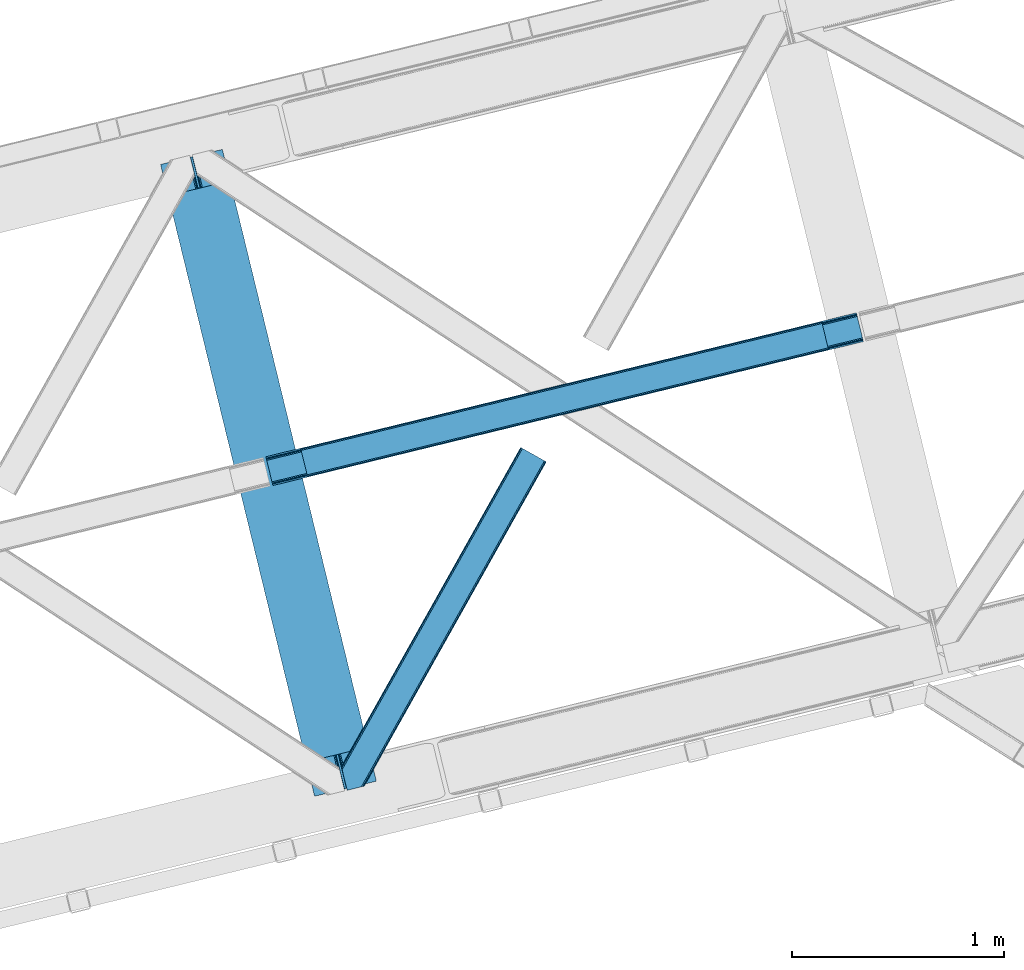
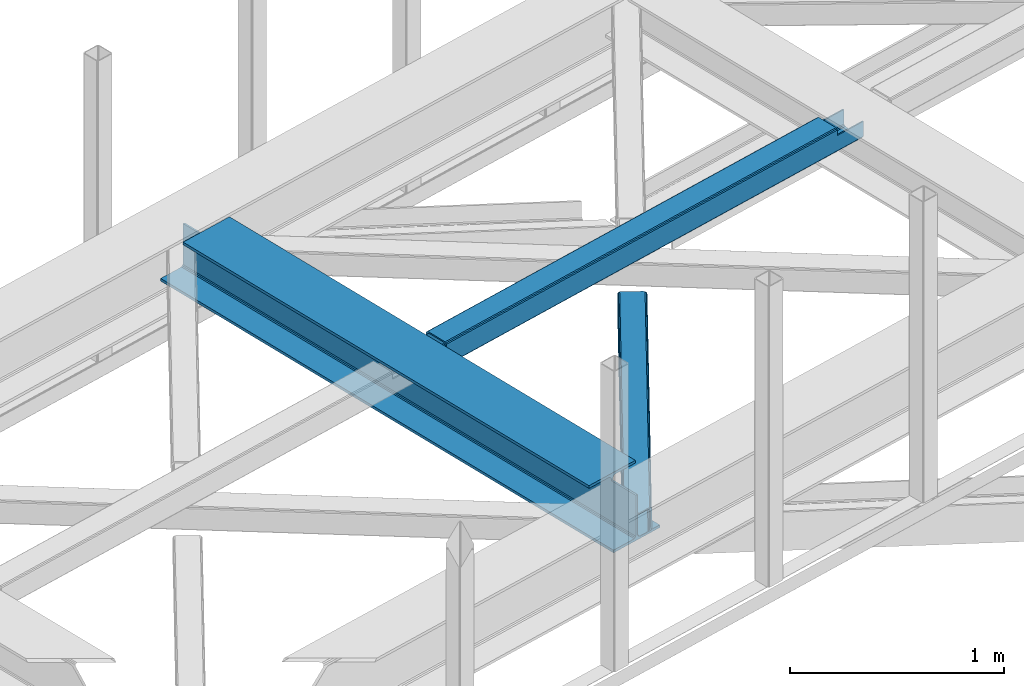
# One storey, part 55 of 66: 2 beams, 1 member.
"""IFC4 building model written with IfcOpenShell, lengths in millimetres."""

from ifc_helpers import new_model, entity, si_unit, converted_unit, derived_unit, direction, frame, origin, place, context, subcontext, project, spatial, triangles, polygons, material, type_object, element, save


model = new_model("IFC4")

# Units and contexts
model_context = context("Model", 3, precision=0.01, world=origin(), true_north=direction((6.12303176911189e-17, 1.0)))
plan_context = context("Plan", 3, precision=0.01, world=origin(), true_north=direction((6.12303176911189e-17, 1.0)))
body_context = subcontext(model_context, "Body", "Model", "MODEL_VIEW")
ifc_project = project(units=[si_unit("LENGTHUNIT", "METRE", prefix="MILLI"), si_unit("AREAUNIT", "SQUARE_METRE"), si_unit("VOLUMEUNIT", "CUBIC_METRE"), converted_unit("PLANEANGLEUNIT", "DEGREE", entity("IfcRatioMeasure", 0.0174532925199433), si_unit("PLANEANGLEUNIT", "RADIAN"), dimensions=[0, 0, 0, 0, 0, 0, 0]), si_unit("MASSUNIT", "GRAM", prefix="KILO"), derived_unit("MASSDENSITYUNIT", [(si_unit("MASSUNIT", "GRAM", prefix="KILO"), 1), (si_unit("LENGTHUNIT", "METRE"), -3)]), derived_unit("MOMENTOFINERTIAUNIT", [(si_unit("LENGTHUNIT", "METRE"), 4)]), si_unit("TIMEUNIT", "SECOND"), si_unit("FREQUENCYUNIT", "HERTZ"), si_unit("THERMODYNAMICTEMPERATUREUNIT", "DEGREE_CELSIUS"), derived_unit("THERMALTRANSMITTANCEUNIT", [(si_unit("MASSUNIT", "GRAM", prefix="KILO"), 1), (si_unit("THERMODYNAMICTEMPERATUREUNIT", "KELVIN"), -1), (si_unit("TIMEUNIT", "SECOND"), -3)]), derived_unit("VOLUMETRICFLOWRATEUNIT", [(si_unit("LENGTHUNIT", "METRE"), 3), (si_unit("TIMEUNIT", "SECOND"), -1)]), derived_unit("MASSFLOWRATEUNIT", [(si_unit("MASSUNIT", "GRAM", prefix="KILO"), 1), (si_unit("TIMEUNIT", "SECOND"), -1)]), derived_unit("ROTATIONALFREQUENCYUNIT", [(si_unit("TIMEUNIT", "SECOND"), -1)]), si_unit("ELECTRICCURRENTUNIT", "AMPERE"), si_unit("ELECTRICVOLTAGEUNIT", "VOLT"), si_unit("POWERUNIT", "WATT"), si_unit("FORCEUNIT", "NEWTON", prefix="KILO"), si_unit("ILLUMINANCEUNIT", "LUX"), si_unit("LUMINOUSFLUXUNIT", "LUMEN"), si_unit("LUMINOUSINTENSITYUNIT", "CANDELA"), derived_unit("USERDEFINED", [(si_unit("MASSUNIT", "GRAM", prefix="KILO"), -1), (si_unit("LENGTHUNIT", "METRE"), -2), (si_unit("TIMEUNIT", "SECOND"), 3), (si_unit("LUMINOUSFLUXUNIT", "LUMEN"), 1)]), derived_unit("LINEARVELOCITYUNIT", [(si_unit("LENGTHUNIT", "METRE"), 1), (si_unit("TIMEUNIT", "SECOND"), -1)]), si_unit("PRESSUREUNIT", "PASCAL"), derived_unit("USERDEFINED", [(si_unit("LENGTHUNIT", "METRE"), -2), (si_unit("MASSUNIT", "GRAM", prefix="KILO"), 1), (si_unit("TIMEUNIT", "SECOND"), -2)]), derived_unit("LINEARFORCEUNIT", [(si_unit("MASSUNIT", "GRAM", prefix="KILO"), 1), (si_unit("LENGTHUNIT", "METRE"), 1), (si_unit("TIMEUNIT", "SECOND"), -2), (si_unit("LENGTHUNIT", "METRE"), -1)]), derived_unit("PLANARFORCEUNIT", [(si_unit("MASSUNIT", "GRAM", prefix="KILO"), 1), (si_unit("LENGTHUNIT", "METRE"), 1), (si_unit("TIMEUNIT", "SECOND"), -2), (si_unit("LENGTHUNIT", "METRE"), -2)])], contexts=[model_context, plan_context])

# Site, building, storey
site_placement = place(None, origin())
site = spatial("IfcSite", under=ifc_project, at=site_placement, CompositionType="ELEMENT")
building_placement = place(site_placement, origin())
building = spatial("IfcBuilding", under=site, at=building_placement, CompositionType="ELEMENT")
storey_placement = place(building_placement, frame((0.0, 0.0, 19800.0)))
storey = spatial("IfcBuildingStorey", under=building, at=storey_placement, Name="06", CompositionType="ELEMENT", Elevation=19800.0)

# Beams
ifc_material = material(Name="Metal painted (White)")
beam_type = type_object("IfcBeamType", PredefinedType="BEAM")
beam_1_placement = place(storey_placement, frame((-9086.33, 15580.04, 3807.02)))
element("IfcBeam", 1, at=beam_1_placement, inside=storey, type_object=beam_type, material=ifc_material, ObjectType="Steel Beam", PredefinedType="BEAM", context=body_context, shape_type="Tessellation", body=[
    polygons([(1018.1664837833, 71.0478278971021, 15.5000000000008), (1018.1664837833, 71.0478278971021, 0.0), (291.465617442452, 3052.25531830421, 0.0), (291.465617442452, 3052.25531830421, 15.5000000000008), (894.779372399334, 40.9709140873313, 15.5000000000008), (168.078506058486, 3022.17840449444, 15.5000000000008), (888.087028625383, 39.3395844888265, 16.8701684147984), (161.386162284532, 3020.54707489594, 16.8701684147984), (882.413533524763, 37.956610033654, 20.7720779386478), (155.712667183913, 3019.16410044077, 20.7720779386478), (878.622625296189, 37.0325360459184, 26.6116982174294), (151.921758955338, 3018.24002645303, 26.6116982174294), (877.291435352789, 36.7080444135029, 33.500000000001), (150.590569011938, 3017.91553482062, 33.500000000001), (140.875048430526, 3015.54727389071, 33.500000000001), (140.875048430525, 3015.54727389071, 259.000000000002), (150.590569011936, 3017.91553482062, 259.000000000002), (0.0, 2981.20749040711, 0.0), (3.24860138789518e-12, 2981.20749040711, 15.4999999999965), (123.387111383965, 3011.28440421689, 15.5000000000008), (130.079455157938, 3012.91573381539, 16.8701684147984), (135.752950258554, 3014.29870827056, 20.7720779386391), (139.543858487129, 3015.2227822583, 26.6116982174294), (877.291435352786, 36.7080444135029, 259.000000000002), (867.575914771374, 34.3397834836014, 259.000000000002), (867.575914771377, 34.3397834836014, 33.500000000001), (866.24472482798, 34.0152918511859, 26.6116982174294), (862.453816599403, 33.0912178634502, 20.7720779386391), (856.780321498787, 31.70824340828, 16.8701684147984), (850.087977724816, 30.0769138097708, 15.5000000000008), (726.700866340855, 0.0, 15.4999999999965), (726.700866340851, 0.0, 0.0), (838.124523615913, 197.385937999181, 259.069791973884), (186.469722099971, 2870.72539801219, 259.000000000002), (186.693115201823, 2869.80895360721, 259.617303331124), (186.70550404545, 2869.75812937344, 266.500003008253), (837.979344808147, 197.981416001704, 266.500002998871), (837.979694928899, 197.979979696973, 260.000004007589), (828.499586345882, 194.645865944434, 259.006343171919), (828.27621632612, 195.562317481914, 259.617303331124), (828.263827482491, 195.613141715687, 266.500003008253), (176.989986719794, 2867.38985508742, 266.500002998871), (176.989636599042, 2867.39129139215, 260.000004007589), (176.844830940702, 2867.98534020594, 259.07612046749), (176.75420151856, 2868.35713708228, 259.000000000002), (839.310832678078, 198.30468544639, 273.388305639783), (843.101109266769, 199.231350618303, 279.227924098777), (848.774180214308, 200.616065081981, 283.129832400619), (855.466371895439, 202.248018612794, 284.500000377228), (978.853400583268, 232.325271667905, 284.500000138971), (978.851730776625, 232.332121736637, 299.999995328161), (687.386308679347, 161.283492472596, 299.999995890962), (687.387978486002, 161.276642403863, 284.500000701776), (810.775007173842, 191.353895458974, 284.500000463519), (817.467494070002, 192.984637925557, 283.129832461069), (823.141405718754, 194.365903570079, 279.227924137322), (826.93294050575, 195.287407219375, 273.388305663684), (175.658498849867, 2867.06658564273, 273.388305639783), (171.868222261169, 2866.13992047082, 279.227924098781), (166.195151313643, 2864.75520600715, 283.129832400619), (159.502959632494, 2863.12325247633, 284.500000377228), (36.1159309446587, 2833.04599942122, 284.500000138971), (36.117600751305, 2833.03914935249, 299.999995328161), (327.583022848581, 2904.08777861653, 299.999995890962), (327.581353041927, 2904.09462868526, 284.500000701776), (204.194324354092, 2874.01737563015, 284.500000463519), (197.50183745795, 2872.38663316357, 283.129832461069), (191.827925809185, 2871.00536751905, 279.227924137318), (188.036391022194, 2870.08386386975, 273.388305663684)], [[[1, 2, 3, 4]], [[5, 1, 4, 6]], [[7, 5, 6, 8]], [[9, 7, 8, 10]], [[11, 9, 10, 12]], [[13, 11, 12, 14]], [[15, 16, 17, 14, 12, 10, 8, 6, 4, 3, 18, 19, 20, 21, 22, 23]], [[13, 24, 25, 26, 27, 28, 29, 30, 31, 32, 2, 1, 5, 7, 9, 11]], [[2, 32, 18, 3]], [[32, 31, 19, 18]], [[31, 30, 20, 19]], [[27, 26, 15, 23]], [[28, 27, 23, 22]], [[29, 28, 22, 21]], [[30, 29, 21, 20]], [[33, 24, 13, 14, 17, 34, 35, 36, 37, 38]], [[25, 39, 40, 41, 42, 43, 44, 16, 15, 26]], [[39, 25, 24, 33]], [[45, 34, 17, 16]], [[41, 40, 38, 37, 46, 47, 48, 49, 50, 51, 52, 53, 54, 55, 56, 57]], [[42, 58, 59, 60, 61, 62, 63, 64, 65, 66, 67, 68, 69, 36, 35, 43]], [[46, 37, 36, 69]], [[47, 46, 69, 68]], [[48, 47, 68, 67]], [[49, 48, 67, 66]], [[50, 49, 66, 65]], [[51, 50, 65, 64]], [[52, 51, 64, 63]], [[53, 52, 63, 62]], [[54, 53, 62, 61]], [[55, 54, 61, 60]], [[56, 55, 60, 59]], [[57, 56, 59, 58]], [[41, 57, 58, 42]]], closed=False),
])
beam_2_placement = place(storey_placement, frame((-8589.6, 17046.14, 3967.02)))
element("IfcBeam", 2, at=beam_2_placement, inside=storey, type_object=beam_type, material=ifc_material, ObjectType="Steel Beam", PredefinedType="BEAM", context=body_context, shape_type="Tessellation", body=[
    polygons([(31.182392391782, 8.09507685196974, 17.8030399336114), (31.4978703677338, 6.80086440699434, 24.4999999999988), (2817.90917311747, 686.01809910328, 24.4999999999988), (2817.59369514152, 687.312311548251, 17.8030399336114), (30.2839871259284, 11.7806820741929, 12.1256313292298), (2816.69528987567, 690.997916770481, 12.1256313292298), (28.9394286278462, 17.2965800886818, 8.33210818105214), (2815.35073137759, 696.513814784967, 8.33210818105214), (27.35341374041, 23.8030254244748, 7.00000000000274), (2813.76471649015, 703.02026012076, 7.00000000000274), (4.21622439085534, 118.720708051138, 8.33210818105214), (5.80223927828939, 112.214262715347, 7.00000000000274), (2792.21354202803, 791.431497411635, 7.00000000000274), (2790.6275271406, 797.937942747428, 8.33210818105214), (2.87166589277206, 124.236606065627, 12.1256313292342), (2789.28296864251, 803.453840761912, 12.1256313292342), (1.97326062691843, 127.922211287854, 17.8030399336114), (2788.38456337666, 807.13944598414, 17.8030399336114), (1.65778265095143, 129.216423732823, 24.4999999999988), (2788.06908540069, 808.433658429109, 24.4999999999988), (33.1556530186549, 2.16573425859679e-12, 17.5000000000004), (33.1556530186528, 2.16573425859679e-12, 99.499999999999), (31.4978703677219, 6.80086440699217, 99.499999999999), (1.6577826509406, 129.216423732817, 99.499999999999), (6.49720277579036e-12, 136.017288139809, 99.499999999999), (9.74580416368554e-12, 136.017288139809, 17.5000000000004), (0.315477975968082, 134.72307569484, 10.803039933613), (1.21388324182172, 131.037470472617, 5.12563132923143), (2.55844173990608, 125.521572458128, 1.33210818105373), (4.14445662734013, 119.015127122333, 0.0), (29.0111963913267, 17.0021610174783, 0.0), (30.5972112787619, 10.4957156816875, 1.33210818105373), (31.9417697768441, 4.97981766719851, 5.12563132923576), (32.8401750426977, 1.29421244497107, 10.803039933613), (2786.41130274974, 815.234522836097, 17.5000000000004), (2786.41130274974, 815.234522836094, 99.499999999999), (2788.06908540067, 808.433658429104, 99.499999999999), (2817.90917311745, 686.018099103278, 99.499999999999), (2819.56695576838, 679.217234696288, 99.499999999999), (2819.56695576839, 679.217234696292, 17.5000000000004), (2819.25147779243, 680.511447141259, 10.803039933613), (2818.35307252658, 684.197052363484, 5.12563132923576), (2817.0085140285, 689.712950377975, 1.33210818105373), (2815.42249914106, 696.219395713764, 0.0), (2790.55575937708, 798.23236181862, 0.0), (2788.96974448964, 804.738807154411, 1.33210818105373), (2787.62518599156, 810.2547051689, 5.12563132923143), (2786.72678072571, 813.94031039113, 10.803039933613), (2653.72536552982, 645.996559503596, 115.5000123926), (2653.78173361469, 646.01029872221, 100.117303289864), (2654.6884273497, 646.231315480905, 99.499999999999), (194.718606580807, 46.58768115868, 99.5063429816656), (195.631369831918, 46.8101414945073, 100.117301735448), (195.690168193629, 46.8244741223611, 115.5), (2656.34621000063, 639.430451073913, 99.499999999999), (2655.43964990838, 639.209466900405, 100.117303484932), (2655.38006714071, 639.194943868063, 122.500007895425), (197.345360928044, 40.0229783796067, 122.500002534479), (197.338587096737, 40.0213271441522, 100.500009163303), (196.748205195732, 39.8773799905108, 99.5697919021647), (2624.8483491876, 768.646841677423, 99.5063429816656), (2623.93924032813, 768.425271514709, 100.117299778624), (2623.88287224327, 768.411532296091, 115.50000888136), (165.850080476843, 169.240033448186, 115.5), (165.840462203339, 169.237688832046, 100.50000941238), (165.250325295041, 169.093836777338, 99.5761204674868), (2622.81875057268, 775.357142845592, 99.5697919021647), (163.22074576778, 175.804071762186, 99.499999999999), (164.133244938518, 176.026503182401, 100.117301984524), (164.189439987629, 176.04020120897, 122.500002796667), (2622.22174126677, 775.211580304176, 122.500003994045), (2622.23184455559, 775.21404371874, 100.500018741102), (2622.53385542114, 773.916547682008, 129.196959150505), (2623.42719094673, 770.229706340318, 134.874360354937), (2624.7684819508, 764.713011635509, 138.667878733795), (2626.35352903681, 758.206330327434, 139.999985502214), (2651.22427808373, 656.194341778123, 139.999991354279), (2652.81177220132, 649.688257112721, 138.667885332354), (2654.16003176176, 644.173261502491, 134.874367586349), (2655.06379646897, 640.488963035541, 129.196966804773), (2653.41217589812, 647.291329899609, 122.196975799125), (2652.50841119091, 650.975628366566, 127.874376580702), (2651.16015163047, 656.490623976793, 131.667894326702), (2649.57265751289, 662.996708642196, 133.000000348631), (2628.01800833888, 751.407098718266, 132.999995276841), (2626.43296125288, 757.913780026341, 131.667888508414), (2625.09167024881, 763.430474731148, 127.874370129564), (2624.19833472322, 767.11731607284, 122.196968925133), (164.878528418714, 169.003207355196, 99.499999999999), (193.131726453735, 57.3201898040421, 131.667891818946), (191.5457115663, 63.826635139835, 133.0), (194.476284951818, 51.8042917895531, 127.874368670764), (195.374690217671, 48.11868656733, 122.196960066391), (169.994537104179, 152.237872430709, 133.0), (166.165558452806, 167.945821003219, 122.196960066391), (167.063963718659, 164.260215780991, 127.874368670764), (168.408522216743, 158.744317766505, 131.667891818946), (197.031411944066, 41.3175635421159, 129.196961104604), (196.136488323058, 45.0040174739003, 134.874366301861), (194.794244157307, 50.5204796458751, 138.667887185257), (193.209023953575, 57.0271186992015, 139.999994588639), (168.341882306934, 159.03998683839, 139.999994981919), (166.755021471182, 165.546225960036, 138.667887628704), (165.408105180725, 171.06154922293, 134.874366787843), (164.506189230959, 174.746298656826, 129.196961619)], [[[1, 2, 3, 4]], [[5, 1, 4, 6]], [[7, 5, 6, 8]], [[9, 7, 8, 10]], [[11, 12, 13, 14]], [[15, 11, 14, 16]], [[17, 15, 16, 18]], [[19, 17, 18, 20]], [[12, 9, 10, 13]], [[21, 22, 23, 2, 1, 5, 7, 9, 12, 11, 15, 17, 19, 24, 25, 26, 27, 28, 29, 30, 31, 32, 33, 34]], [[35, 36, 37, 20, 18, 16, 14, 13, 10, 8, 6, 4, 3, 38, 39, 40, 41, 42, 43, 44, 45, 46, 47, 48]], [[49, 50, 51, 38, 3, 2, 23, 52, 53, 54]], [[55, 39, 38, 51]], [[39, 55, 56, 57, 58, 59, 60, 22, 21, 40]], [[32, 31, 44, 43]], [[33, 32, 43, 42]], [[34, 33, 42, 41]], [[21, 34, 41, 40]], [[31, 30, 45, 44]], [[27, 26, 35, 48]], [[28, 27, 48, 47]], [[29, 28, 47, 46]], [[30, 29, 46, 45]], [[20, 37, 61, 62, 63, 64, 65, 66, 24, 19]], [[67, 36, 35, 26, 25, 68, 69, 70, 71, 72]], [[36, 67, 61, 37]], [[72, 71, 73, 74, 75, 76, 77, 78, 79, 80, 57, 56, 50, 49, 81, 82, 83, 84, 85, 86, 87, 88, 63, 62]], [[60, 52, 23, 22]], [[25, 24, 89, 68]], [[90, 91, 84, 83]], [[92, 90, 83, 82]], [[93, 92, 82, 81]], [[54, 93, 81, 49]], [[94, 85, 84, 91]], [[95, 64, 63, 88]], [[96, 95, 88, 87]], [[97, 96, 87, 86]], [[94, 97, 86, 85]], [[65, 64, 95, 96, 97, 94, 91, 90, 92, 93, 54, 53, 59, 58, 98, 99, 100, 101, 102, 103, 104, 105, 70, 69]], [[98, 58, 57, 80]], [[99, 98, 80, 79]], [[100, 99, 79, 78]], [[101, 100, 78, 77]], [[77, 76, 102, 101]], [[103, 102, 76, 75]], [[104, 103, 75, 74]], [[105, 104, 74, 73]], [[70, 105, 73, 71]]], closed=False),
])

# Member
member_type = type_object("IfcMemberType", PredefinedType="BRACE")
member_placement = place(storey_placement, frame((-8233.36, 15608.24, 3823.0)))
element("IfcMember", 3, at=member_placement, inside=storey, type_object=member_type, ObjectType="Steel Horizontal Brace", PredefinedType="BRACE", context=body_context, shape_type="Tessellation", body=[
    triangles([(967.681050109863, 1549.66471252441, 122.499499511719), (966.521237182617, 1550.31699829101, 129.196765136719), (108.493377685547, 19.761584472657, 122.499499511719), (106.721974182128, 19.3302154541016, 129.196765136719), (963.215043640136, 1552.17502441406, 134.87548828125), (101.679258728027, 18.1012207031254, 134.87548828125), (958.263020324707, 1554.95392456055, 138.668280029298), (94.1378585815428, 16.2629608154293, 138.668280029298), (952.422679138183, 1558.23395690918, 140.00075683594), (85.2360763549805, 14.0921630859375, 140.00075683594), (967.681050109863, 1549.66471252441, 17.5012573242202), (108.493377685547, 19.761584472657, 17.5012573242202), (6.07462921142542, 87.5702362060547, 140.00075683594), (27.4210006713856, 0.0, 140.00075683594), (860.874778747559, 1609.64826049805, 140.00075683594), (855.034437561035, 1612.92829284668, 138.668280029298), (3.74977111816406, 97.1068634033199, 138.668280029298), (850.082414245605, 1615.70719299316, 134.87548828125), (1.77896118164063, 105.192416381837, 134.87548828125), (846.776220703125, 1617.56521911621, 129.196765136719), (0.462181091308594, 110.594412231445, 129.196765136719), (845.616407775879, 1618.21750488281, 122.499499511719), (0.0, 112.491970825195, 122.499499511719), (845.616407775879, 1618.21750488281, 17.5012573242202), (0.0, 112.491970825195, 17.5012573242202), (966.521237182617, 1550.31699829101, 10.8039916992202), (106.721974182128, 19.3302154541016, 10.8039916992202), (156.767756652832, 115.413885498047, 5.52059326172093), (963.215043640136, 1552.17502441406, 5.12526855468968), (156.952047729492, 116.778918457032, 5.02062377929906), (102.189692687988, 18.2256317138672, 5.52059326172093), (958.263020324707, 1554.95392456055, 1.33247680664135), (157.131687927245, 118.142788696288, 4.52065429687718), (155.381794738769, 125.321420288086, 1.33247680664135), (952.422679138183, 1558.23395690918, 0.0), (153.056936645507, 134.858047485352, 0.0), (124.438916015624, 252.261346435547, 0.0), (94.4628387451166, 244.953652954102, 0.0), (860.874778747559, 1609.64826049805, 0.0), (77.5132919311518, 240.822509765625, 5.52059326172093), (85.5657073974608, 242.785180664063, 1.33247680664135), (123.842440795898, 252.116006469727, 5.44385375976708), (124.438916015624, 252.261346435547, 4.52065429687718), (846.776220703125, 1617.56521911621, 10.8039916992202), (1.68013000488281, 112.178036499023, 10.9621215820334), (0.251147460936409, 111.460638427734, 12.5201660156272), (850.082414245605, 1615.70719299316, 5.12526855468968), (855.034437561035, 1612.92829284668, 1.33247680664135), (6.66994171142505, 114.682534790039, 5.52059326172093), (34.2211669921871, 1.65687561035156, 5.52059326172093), (123.467463684082, 252.024151611327, 5.52059326172093), (32.7846267700188, 1.30689697265552, 6.99957275390625), (12.4672622680664, 84.6564605712883, 6.99957275390625), (9.18839263916016, 92.4908660888668, 8.3320495605476), (4.07649536132703, 95.7674102783203, 12.5201660156272), (75.9366439819332, 11.8260223388679, 6.99957275390625), (946.321307373047, 1561.66165466309, 6.99957275390625), (866.976150512695, 1606.22056274414, 6.99957275390625), (861.135809326172, 1609.49943237305, 8.3320495605476), (856.187855529784, 1612.28065795899, 12.1248413085959), (852.877592468261, 1614.1375213623, 17.8035644531265), (2.89226531982422, 100.625253295899, 17.8035644531265), (851.717779541015, 1614.78980712891, 24.5008300781265), (2.43008422851563, 102.522811889648, 24.5008300781265), (961.579678344727, 1553.09241027832, 24.5008300781265), (960.415214538574, 1553.7435333252, 17.8035644531265), (99.1892944335932, 17.4942810058601, 24.5008300781265), (97.4178909301754, 17.0617492675774, 17.8035644531265), (957.109602355957, 1555.60155944824, 12.1248413085959), (92.3798263549797, 15.8339172363285, 12.1248413085959), (952.16164855957, 1558.38278503418, 8.3320495605476), (84.8337753295891, 13.994494628907, 8.3320495605476), (961.579678344727, 1553.09241027832, 115.499926757813), (99.1892944335932, 17.4942810058601, 115.499926757813), (84.8337753295891, 13.994494628907, 131.668707275392), (75.9366439819332, 11.8260223388679, 133.001184082033), (27.4210006713856, 0.0, 133.001184082033), (92.3798263549797, 15.8339172363285, 127.873590087893), (97.4178909301754, 17.0617492675774, 122.197192382813), (946.321307373047, 1561.66165466309, 133.001184082033), (952.16164855957, 1558.38278503418, 131.668707275392), (957.109602355957, 1555.60155944824, 127.873590087893), (960.415214538574, 1553.7435333252, 122.197192382813), (856.187855529784, 1612.28065795899, 127.873590087893), (866.976150512695, 1606.22056274414, 133.001184082033), (861.135809326172, 1609.49943237305, 131.668707275392), (851.717779541015, 1614.78980712891, 115.499926757813), (852.877592468261, 1614.1375213623, 122.197192382813), (4.20904541015625, 95.2232574462887, 127.873590087893), (2.89226531982422, 100.625253295899, 122.197192382813), (6.17985534667969, 87.1377044677738, 131.668707275392), (8.50471343994104, 77.6010772705085, 133.001184082033), (2.43008422851563, 102.522811889648, 115.499926757813)], [[1, 2, 3], [4, 3, 2], [2, 5, 4], [6, 4, 5], [5, 7, 6], [8, 6, 7], [7, 9, 8], [10, 8, 9], [11, 1, 3], [3, 12, 11], [13, 10, 9], [10, 13, 14], [9, 15, 13], [15, 16, 17], [17, 13, 15], [16, 18, 19], [19, 17, 16], [18, 20, 21], [21, 19, 18], [20, 22, 23], [23, 21, 20], [22, 24, 25], [25, 23, 22], [26, 27, 28], [28, 29, 26], [28, 30, 29], [27, 31, 28], [30, 32, 29], [30, 33, 32], [33, 34, 32], [35, 32, 36], [34, 36, 32], [26, 11, 12], [12, 27, 26], [37, 38, 39], [36, 37, 35], [39, 35, 37], [38, 40, 41], [38, 37, 42], [38, 42, 40], [42, 37, 43], [43, 36, 33], [36, 43, 37], [34, 33, 36], [24, 44, 45], [45, 46, 24], [47, 48, 41], [45, 44, 40], [44, 47, 40], [40, 49, 45], [41, 40, 47], [48, 39, 38], [38, 41, 48], [46, 25, 24], [31, 49, 28], [31, 50, 49], [40, 28, 49], [51, 28, 40], [50, 52, 53], [49, 53, 54], [53, 49, 50], [55, 45, 49], [49, 54, 55], [46, 45, 55], [53, 56, 57], [56, 53, 52], [57, 58, 53], [59, 60, 55], [60, 61, 62], [62, 55, 60], [61, 63, 64], [64, 62, 61], [58, 59, 54], [54, 53, 58], [55, 54, 59], [65, 66, 67], [68, 67, 66], [66, 69, 68], [70, 68, 69], [69, 71, 70], [72, 70, 71], [71, 57, 72], [56, 72, 57], [73, 65, 67], [67, 74, 73], [8, 10, 75], [14, 76, 10], [76, 14, 77], [76, 75, 10], [78, 8, 75], [78, 6, 8], [6, 79, 4], [79, 6, 78], [3, 79, 74], [79, 3, 4], [56, 31, 72], [68, 70, 31], [70, 72, 31], [56, 50, 31], [50, 56, 52], [67, 68, 12], [27, 12, 68], [3, 67, 12], [67, 3, 74], [68, 31, 27], [80, 81, 75], [75, 76, 80], [81, 82, 78], [78, 75, 81], [82, 83, 79], [79, 78, 82], [83, 73, 74], [74, 79, 83], [26, 69, 66], [65, 1, 11], [26, 66, 11], [26, 29, 69], [66, 65, 11], [69, 29, 32], [57, 35, 39], [35, 71, 32], [71, 35, 57], [71, 69, 32], [2, 82, 5], [73, 1, 65], [1, 83, 2], [83, 1, 73], [2, 83, 82], [9, 80, 15], [7, 5, 82], [82, 81, 7], [81, 80, 9], [9, 7, 81], [60, 48, 47], [39, 58, 57], [39, 59, 58], [59, 39, 48], [60, 59, 48], [63, 24, 22], [44, 61, 60], [47, 44, 60], [61, 44, 24], [63, 61, 24], [16, 84, 18], [15, 80, 85], [85, 86, 15], [86, 84, 16], [16, 15, 86], [20, 18, 84], [22, 87, 63], [88, 22, 20], [22, 88, 87], [88, 20, 84], [89, 19, 90], [91, 92, 13], [92, 14, 13], [92, 77, 14], [17, 91, 13], [89, 17, 19], [89, 91, 17], [23, 64, 93], [21, 90, 19], [93, 90, 23], [90, 21, 23], [25, 64, 23], [46, 55, 62], [62, 64, 25], [25, 46, 62], [76, 92, 80], [76, 77, 92], [85, 80, 92], [63, 87, 93], [93, 64, 63], [87, 88, 93], [90, 93, 88], [88, 84, 90], [89, 90, 84], [84, 86, 89], [91, 89, 86], [86, 85, 91], [92, 91, 85]]),
])

save(model, "model.ifc")
